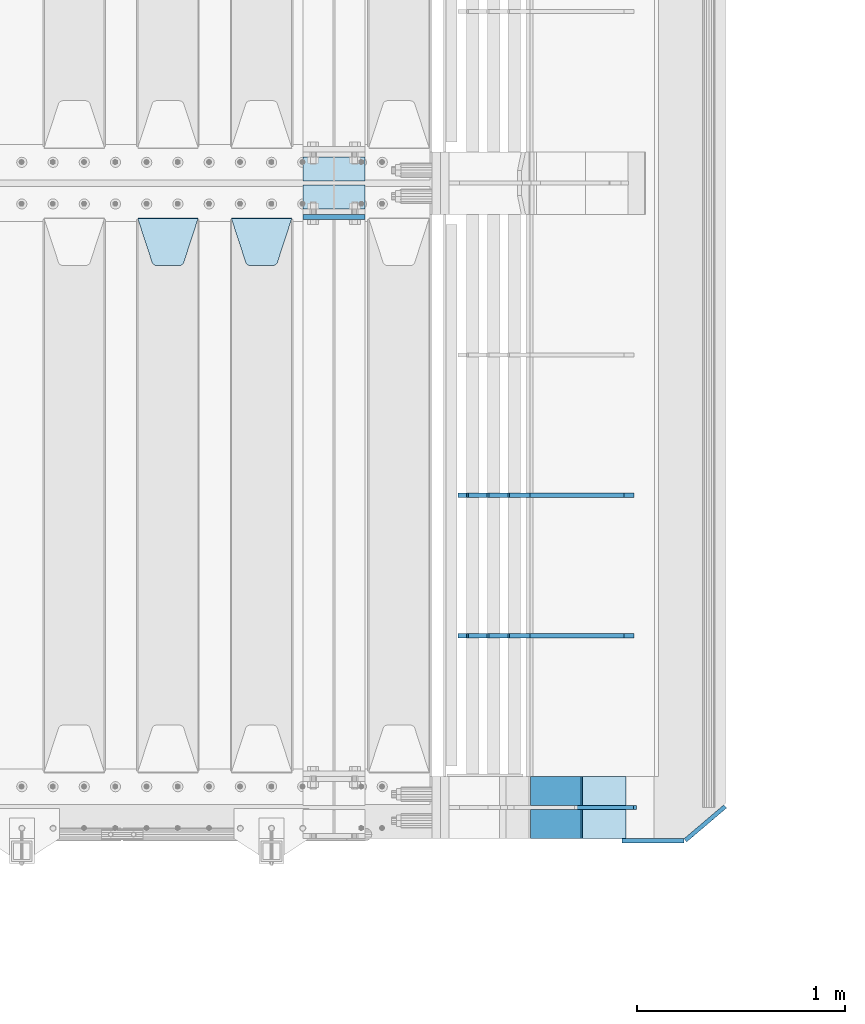
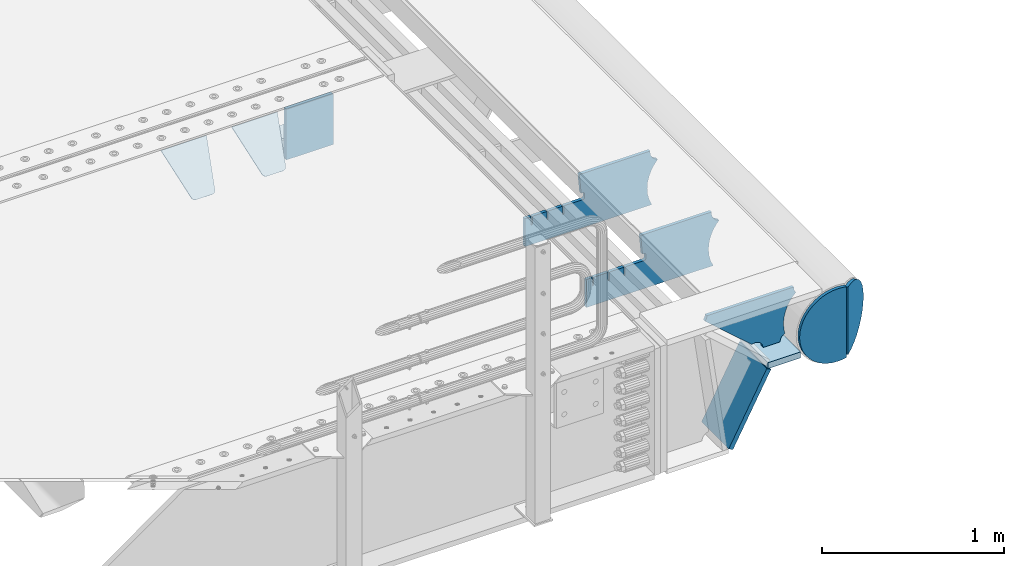
# One storey, part 220 of 242: 12 plates.
"""IFC2X3 building model written with IfcOpenShell, lengths in millimetres."""

from ifc_helpers import new_model, si_unit, frame, origin_with_axes, place, context, subcontext, project, spatial, faceted_brep, material, type_object, element, save


model = new_model("IFC2X3")

# Units and contexts
model_context = context("Model", 3, precision=1e-05, world=origin_with_axes())
body_context = subcontext(model_context, "Body", "Model", "MODEL_VIEW")
ifc_project = project(units=[si_unit("LENGTHUNIT", "METRE", prefix="MILLI"), si_unit("AREAUNIT", "SQUARE_METRE"), si_unit("VOLUMEUNIT", "CUBIC_METRE"), si_unit("MASSUNIT", "GRAM", prefix="KILO"), si_unit("TIMEUNIT", "SECOND"), si_unit("PLANEANGLEUNIT", "RADIAN"), si_unit("SOLIDANGLEUNIT", "STERADIAN"), si_unit("THERMODYNAMICTEMPERATUREUNIT", "DEGREE_CELSIUS"), si_unit("LUMINOUSINTENSITYUNIT", "LUMEN")], contexts=[model_context])

# Site, building, storey
site_placement = place(None, origin_with_axes())
site = spatial("IfcSite", under=ifc_project, at=site_placement, CompositionType="ELEMENT")
building_placement = place(site_placement, origin_with_axes())
building = spatial("IfcBuilding", under=site, at=building_placement, Name="Standard", CompositionType="ELEMENT")
storey_placement = place(building_placement, origin_with_axes())
storey = spatial("IfcBuildingStorey", under=building, at=storey_placement, Name="Undefined", CompositionType="ELEMENT", Elevation=0.0)

# Plates
ifc_material = material(Name="STEEL/S355N")
plate_type_1 = type_object("IfcPlateType", PredefinedType="NOTDEFINED")
plate_1_placement = place(storey_placement, frame((-22682.0, -21162.5, -340.000000000044), z_axis=(0.0, 0.0, 1.0), x_axis=(1.0, 0.0, 0.0)))
element("IfcPlate", 1, at=plate_1_placement, inside=storey, type_object=plate_type_1, material=ifc_material, context=body_context, shape_type="Brep", body=[
    faceted_brep([(0.0, -12.5, 0.0), (9.27684595808387e-10, -12.5, 340.0), (9.27684595808387e-10, 12.5, 340.0), (0.0, 12.5, 0.0), (300.0, -12.5, 340.0), (300.0, 12.5, 340.0), (300.0, -12.5, 0.0), (300.0, 12.5, 0.0)], [[[0, 1, 2, 3]], [[1, 4, 5, 2]], [[4, 6, 7, 5]], [[6, 0, 3, 7]], [[5, 7, 3, 2]], [[6, 4, 1, 0]]]),
])
plate_type_2 = type_object("IfcPlateType", PredefinedType="NOTDEFINED")
plate_2_placement = place(storey_placement, frame((-23025.0, -21168.232233044, -1.76776695296576), z_axis=(0.0, -0.707106781186547, -0.707106781186548), x_axis=(1.0, 0.0, 0.0)))
element("IfcPlate", 2, at=plate_2_placement, inside=storey, type_object=plate_type_2, material=ifc_material, context=body_context, shape_type="Brep", body=[
    faceted_brep([(0.0, -2.5, 0.0), (69.345504679477, -2.50000000000182, 300.171731424829), (69.345504679477, 2.5, 300.171731424829), (0.0, 2.5, 0.0), (70.9274061199576, -2.5, 304.897442415398), (70.9274061199576, 2.5, 304.897442415398), (73.3818627772307, -2.5, 309.234538108525), (73.3818627772307, 2.50000000000182, 309.234538108529), (76.6187032999551, -2.5, 313.023683126101), (76.6187032999551, 2.50000000000182, 313.023683126103), (80.5190132704993, -2.5, 316.12567259537), (80.5190132704993, 2.5, 316.12567259537), (84.9395038596849, -2.5, 318.426546230474), (84.9395038596849, 2.50000000000182, 318.426546230476), (89.7177759439219, -2.49999999999818, 319.841774983273), (89.7177759439219, 2.50000000000182, 319.841774983273), (94.678286292652, -2.5, 320.319366455076), (94.678286292652, 2.5, 320.319366455076), (195.321713707348, -2.5, 320.319366455076), (195.321713707348, 2.5, 320.319366455076), (200.282224056078, -2.5, 319.841774983272), (200.282224056078, 2.50000000000182, 319.841774983273), (205.060496140315, -2.5, 318.426546230474), (205.060496140315, 2.49999999999818, 318.426546230474), (209.480986729501, -2.49999999999818, 316.12567259537), (209.480986729501, 2.5, 316.12567259537), (213.381296700045, -2.5, 313.023683126101), (213.381296700045, 2.49999999999818, 313.023683126101), (216.618137222769, -2.5, 309.234538108525), (216.618137222769, 2.5, 309.234538108523), (219.072593880042, -2.49999999999818, 304.897442415398), (219.072593880042, 2.50000000000182, 304.897442415398), (220.654495320523, -2.50000000000182, 300.171731424829), (220.654495320523, 2.5, 300.171731424829), (290.0, -2.5, 0.0), (290.0, 2.5, -1.81898940354586e-12)], [[[0, 1, 2, 3]], [[1, 4, 5, 2]], [[4, 6, 7, 5]], [[6, 8, 9, 7]], [[8, 10, 11, 9]], [[10, 12, 13, 11]], [[12, 14, 15, 13]], [[14, 16, 17, 15]], [[16, 18, 19, 17]], [[18, 20, 21, 19]], [[20, 22, 23, 21]], [[22, 24, 25, 23]], [[24, 26, 27, 25]], [[26, 28, 29, 27]], [[28, 30, 31, 29]], [[30, 32, 33, 31]], [[32, 34, 35, 33]], [[34, 0, 3, 35]], [[5, 7, 9, 11, 13, 15, 17, 19, 21, 23, 25, 27, 29, 31, 33, 35, 3, 2]], [[34, 32, 30, 28, 26, 24, 22, 20, 18, 16, 14, 12, 10, 8, 6, 4, 1, 0]]]),
])
plate_3_placement = place(storey_placement, frame((-23475.0, -21168.232233044, -1.76776695296576), z_axis=(0.0, -0.707106781186547, -0.707106781186548), x_axis=(1.0, 0.0, 0.0)))
element("IfcPlate", 3, at=plate_3_placement, inside=storey, type_object=plate_type_2, material=ifc_material, context=body_context, shape_type="Brep", body=[
    faceted_brep([(0.0, -2.5, 0.0), (69.345504679477, -2.50000000000182, 300.171731424829), (69.345504679477, 2.5, 300.171731424829), (0.0, 2.5, 0.0), (70.9274061199576, -2.5, 304.897442415398), (70.9274061199576, 2.5, 304.897442415398), (73.3818627772307, -2.5, 309.234538108525), (73.3818627772307, 2.50000000000182, 309.234538108529), (76.6187032999551, -2.5, 313.023683126101), (76.6187032999551, 2.50000000000182, 313.023683126103), (80.5190132704993, -2.5, 316.12567259537), (80.5190132704993, 2.5, 316.12567259537), (84.9395038596849, -2.5, 318.426546230474), (84.9395038596849, 2.50000000000182, 318.426546230476), (89.7177759439219, -2.49999999999818, 319.841774983273), (89.7177759439219, 2.50000000000182, 319.841774983273), (94.678286292652, -2.5, 320.319366455076), (94.678286292652, 2.5, 320.319366455076), (195.321713707348, -2.5, 320.319366455076), (195.321713707348, 2.5, 320.319366455076), (200.282224056078, -2.5, 319.841774983272), (200.282224056078, 2.50000000000182, 319.841774983273), (205.060496140315, -2.5, 318.426546230474), (205.060496140315, 2.49999999999818, 318.426546230474), (209.480986729501, -2.49999999999818, 316.12567259537), (209.480986729501, 2.5, 316.12567259537), (213.381296700045, -2.5, 313.023683126101), (213.381296700045, 2.49999999999818, 313.023683126101), (216.618137222769, -2.5, 309.234538108525), (216.618137222769, 2.5, 309.234538108523), (219.072593880042, -2.49999999999818, 304.897442415398), (219.072593880042, 2.50000000000182, 304.897442415398), (220.654495320523, -2.50000000000182, 300.171731424829), (220.654495320523, 2.5, 300.171731424829), (290.0, -2.5, 0.0), (290.0, 2.5, -1.81898940354586e-12)], [[[0, 1, 2, 3]], [[1, 4, 5, 2]], [[4, 6, 7, 5]], [[6, 8, 9, 7]], [[8, 10, 11, 9]], [[10, 12, 13, 11]], [[12, 14, 15, 13]], [[14, 16, 17, 15]], [[16, 18, 19, 17]], [[18, 20, 21, 19]], [[20, 22, 23, 21]], [[22, 24, 25, 23]], [[24, 26, 27, 25]], [[26, 28, 29, 27]], [[28, 30, 31, 29]], [[30, 32, 33, 31]], [[32, 34, 35, 33]], [[34, 0, 3, 35]], [[5, 7, 9, 11, 13, 15, 17, 19, 21, 23, 25, 27, 29, 31, 33, 35, 3, 2]], [[34, 32, 30, 28, 26, 24, 22, 20, 18, 16, 14, 12, 10, 8, 6, 4, 1, 0]]]),
])
plate_type_3 = type_object("IfcPlateType", PredefinedType="NOTDEFINED")
plate_4_placement = place(storey_placement, frame((-21338.0011701102, -24150.0000000008, -387.999999998984), z_axis=(1.0, 0.0, 0.0), x_axis=(0.0, 1.0, 0.0)))
element("IfcPlate", 4, at=plate_4_placement, inside=storey, type_object=plate_type_3, material=ifc_material, context=body_context, shape_type="Brep", body=[
    faceted_brep([(0.0, -20.0, 0.0), (3.31056071445346e-10, -20.0, 208.0), (3.31056071445346e-10, 20.0, 208.0), (0.0, 20.0, 0.0), (300.0, -20.0, 208.0), (300.0, 20.0, 208.0), (300.0, -20.0, 3.63797880709171e-12), (300.0, 20.0, 3.63797880709171e-12)], [[[0, 1, 2, 3]], [[1, 4, 5, 2]], [[4, 6, 7, 5]], [[6, 0, 3, 7]], [[5, 7, 3, 2]], [[6, 4, 1, 0]]]),
])
plate_type_4 = type_object("IfcPlateType", PredefinedType="NOTDEFINED")
plate_5_placement = place(storey_placement, frame((-21573.7531990427, -23849.999999999, -867.038754737719), z_axis=(0.469471552246176, 0.0, 0.882947598462992), x_axis=(0.0, -1.0, 0.0)))
element("IfcPlate", 5, at=plate_5_placement, inside=storey, type_object=plate_type_4, material=ifc_material, context=body_context, shape_type="Brep", body=[
    faceted_brep([(0.0, -15.0, 0.0), (0.0, -15.0000000000036, 515.0), (0.0, 15.0, 515.000000000002), (0.0, 15.0, 0.0), (300.0, -15.0000000000036, 515.0), (300.0, 15.0, 515.000000000002), (300.0, -15.0, 0.0), (300.0, 15.0, 0.0)], [[[0, 1, 2, 3]], [[1, 4, 5, 2]], [[4, 6, 7, 5]], [[6, 0, 3, 7]], [[5, 7, 3, 2]], [[6, 4, 1, 0]]]),
])
plate_type_5 = type_object("IfcPlateType", PredefinedType="NOTDEFINED")
plate_6_placement = place(storey_placement, frame((-21023.0011701102, -24000.0000000006, -29.9999999989843), z_axis=(-0.000446694000102124, 0.0, -0.99999990023223), x_axis=(-0.99999990023223, 0.0, 0.000446694000103734)))
element("IfcPlate", 6, at=plate_6_placement, inside=storey, type_object=plate_type_5, material=ifc_material, context=body_context, shape_type="Brep", body=[
    faceted_brep([(125.007775472979, 10.0, 291.842314882029), (131.755016800049, 10.0, 263.793234614468), (131.755016800049, -10.0, 263.793234614468), (125.007775472979, -10.0, 291.842314882029), (134.899927074479, 10.0, 224.060281342732), (134.899927074479, -10.0, 224.060281342732), (131.790514995217, 10.0, 184.324534302446), (131.790514995217, -10.0, 184.324534302446), (122.503344607205, 10.0, 145.564419461128), (122.503344607205, -10.0, 145.564419461128), (107.267096867741, 10.0, 108.734339483615), (107.267096867741, -10.0, 108.734339483615), (86.4569387623887, 10.0, 74.7411731709829), (86.4569387623887, -10.0, 74.7411731709829), (60.5852854486475, 10.0, 44.4219450946983), (60.5852854486475, -10.0, 44.4219450946983), (56.2519855253086, 10.0, 40.7176084148888), (56.2519855253086, -10.0, 40.7176084148888), (136.409234539125, -10.0, 297.721677540594), (147.386991180581, -10.0, 308.778803581017), (147.386991180581, 10.0, 308.778803581017), (136.409234539125, 10.0, 297.721677540594), (154.428166132755, -10.0, 322.678193223937), (154.428166132755, 10.0, 322.678193223937), (156.849001662973, -10.0, 338.070097995228), (156.849001662973, 10.0, 338.070097995228), (264.849004013293, -10.0, 338.118348049693), (264.849004013293, 10.0, 338.118348049693), (267.62876711955, -10.0, 321.701412969031), (267.62876711955, 10.0, 321.701412969031), (275.645118712175, -10.0, 307.107546191754), (275.645118712175, 10.0, 307.107546191754), (288.009068357209, -10.0, 295.955165748785), (288.009068357209, 10.0, 295.955165748785), (303.34948944753, -10.0, 289.481038692482), (303.34948944753, 10.0, 289.481038692482), (319.965173216922, -10.0, 288.403127172445), (319.965173216922, 10.0, 288.403127172445), (336.013487920231, -10.0, 292.840968489265), (336.013487920231, 10.0, 292.840968489265), (335.86907958984, -10.0, 293.150054931641), (335.86907958984, 10.0, 293.150054931641), (633.93705743644, -10.0, 32.8861672876964), (633.93705743644, 10.0, 32.8861672876964), (628.672097726398, -10.0, 25.6357574923157), (628.672097726398, 10.0, 25.6357574923157), (624.785781531267, -10.0, 17.5620477266101), (624.785781531267, 10.0, 17.5620477266101), (622.402919050597, -10.0, 8.92432757904925), (622.402919050597, 10.0, 8.92432757904925), (621.600036621094, -10.0, -8.74685213148041e-10), (621.600036621094, 10.0, -8.74685213148041e-10), (69.9999999999964, -10.0, -9.85096448857803e-11), (69.9999999999964, 10.0, -9.85096448857803e-11), (67.7728137216582, -10.0, 17.5170123094482), (67.7728137216582, 10.0, 17.5170123094482), (61.2329794213947, -10.0, 33.9193489203214), (61.2329794213947, 10.0, 33.9193489203214)], [[[0, 1, 2, 3]], [[4, 5, 2, 1]], [[6, 7, 5, 4]], [[8, 9, 7, 6]], [[10, 11, 9, 8]], [[12, 13, 11, 10]], [[14, 15, 13, 12]], [[16, 17, 15, 14]], [[18, 19, 20, 21]], [[19, 22, 23, 20]], [[22, 24, 25, 23]], [[24, 26, 27, 25]], [[26, 28, 29, 27]], [[28, 30, 31, 29]], [[30, 32, 33, 31]], [[32, 34, 35, 33]], [[34, 36, 37, 35]], [[36, 38, 39, 37]], [[38, 40, 41, 39]], [[40, 42, 43, 41]], [[42, 44, 45, 43]], [[44, 46, 47, 45]], [[46, 48, 49, 47]], [[48, 50, 51, 49]], [[50, 52, 53, 51]], [[52, 54, 55, 53]], [[54, 56, 57, 55]], [[12, 10, 8, 6, 4, 1, 0, 21, 20, 23, 25, 27, 29, 31, 33, 35, 37, 39, 41, 43, 45, 47, 49, 51, 53, 55, 57, 16, 14]], [[18, 21, 0, 3]], [[56, 54, 52, 50, 48, 46, 44, 42, 40, 38, 36, 34, 32, 30, 28, 26, 24, 22, 19, 18, 3, 2, 5, 7, 9, 11, 13, 15, 17]], [[57, 56, 17, 16]]]),
])
plate_type_6 = type_object("IfcPlateType", PredefinedType="NOTDEFINED")
plate_7_placement = place(storey_placement, frame((-21094.0817660324, -23175.0007171631, -374.002067436517), z_axis=(0.0, 0.0, 1.0), x_axis=(-1.0, 0.0, 0.0)))
element("IfcPlate", 7, at=plate_7_placement, inside=storey, type_object=plate_type_6, material=ifc_material, context=body_context, shape_type="Brep", body=[
    faceted_brep([(801.919404066546, -10.0, 188.0), (801.919404066546, 10.0, 188.0), (801.919404066546, 10.0, 132.002067436952), (801.919404066546, -10.0, 132.002067436952), (793.919404066546, 10.0, 132.002067436952), (793.919404066546, -10.0, 132.002067436952), (793.919404066546, 10.0, 180.002067436952), (793.919404066546, -10.0, 180.002067436952), (793.527856196906, 10.0, 182.474203391951), (793.527856196906, -10.0, 182.474203391951), (792.391540021545, 10.0, 184.704349455291), (792.391540021545, -10.0, 184.704349455291), (790.621686084887, 10.0, 186.474203391951), (790.621686084887, -10.0, 186.474203391951), (788.391540021545, 10.0, 187.610519567313), (788.391540021545, -10.0, 187.610519567313), (785.919404066546, -10.0, 188.002067436952), (785.919404066546, 10.0, 188.0), (841.0, -10.0, 188.0), (841.0, -10.0, 0.0), (841.0, 10.0, 0.0), (841.0, 10.0, 188.0), (33.3619566735979, -10.0, 0.0), (33.3619566735979, 10.0, 0.0), (36.2350612208174, -10.0, 4.68848050267007), (36.2350612208174, 10.0, 4.68848050267007), (51.4877592159428, -10.0, 41.5117508652783), (51.4877592159428, 10.0, 41.5117508652783), (60.792242588137, -10.0, 80.2677133162963), (60.792242588137, 10.0, 80.2677133162963), (63.9194040769726, -10.0, 120.002067436515), (63.9194040769726, 10.0, 120.002067436515), (60.792242588137, -10.0, 159.736421556734), (60.792242588137, 10.0, 159.736421556734), (51.4877592159428, -10.0, 198.492384007752), (51.4877592159428, 10.0, 198.492384007752), (36.2350612208174, -10.0, 235.31565437036), (36.2350612208174, 10.0, 235.31565437036), (15.4097206482074, -10.0, 269.299521518803), (15.4097206482074, 10.0, 269.299521518803), (-3.35474438098754, -10.0, 291.269887256574), (-3.35474438098754, 10.0, 291.269887256574), (-2.36881039375294, -10.0, 291.426043859339), (-2.36881039375294, 10.0, 291.426043859339), (17.1449676604716, -10.0, 301.368810393754), (17.1449676604716, 10.0, 301.368810393754), (32.6311896062471, -10.0, 316.855032339527), (32.6311896062471, 10.0, 316.855032339527), (42.573956140659, -10.0, 336.368810393754), (42.573956140659, 10.0, 336.368810393754), (46.0, -10.0, 358.0), (46.0, 10.0, 358.0), (45.0495205499137, -10.0, 364.001091067617), (45.0495205499137, 10.0, 364.001091067617), (495.040008544922, -10.0, 364.010009765625), (495.040008544922, 10.0, 364.010009765625), (483.600036621094, -10.0, 233.759994506836), (483.600036621094, 10.0, 233.759994506836), (472.0, -10.0, 233.759994506836), (472.0, 10.0, 233.759994506836), (468.909830056251, -10.0, 233.270559669787), (468.909830056251, 10.0, 233.270559669787), (466.122147477075, -10.0, 231.850164450585), (466.122147477075, 10.0, 231.850164450585), (463.909830056251, -10.0, 229.637847029761), (463.909830056251, 10.0, 229.637847029761), (462.489434837047, -10.0, 226.850164450585), (462.489434837047, 10.0, 226.850164450585), (462.0, -10.0, 223.759994506836), (462.0, 10.0, 223.759994506836), (462.0, -10.0, 198.0), (462.0, 10.0, 198.0), (462.489434837047, -10.0, 194.909830056251), (462.489434837047, 10.0, 194.909830056251), (463.909830056251, -10.0, 192.122147477075), (463.909830056251, 10.0, 192.122147477075), (466.122147477075, -10.0, 189.909830056251), (466.122147477075, 10.0, 189.909830056251), (468.909830056251, -10.0, 188.489434837048), (468.909830056251, 10.0, 188.489434837048), (472.0, -10.0, 188.0), (472.0, 10.0, 188.0), (585.919404066546, -10.0, 188.002067436952), (585.919404066546, 10.0, 188.0), (588.391540021545, -10.0, 187.610519567313), (588.391540021545, 10.0, 187.610519567313), (590.621686084887, -10.0, 186.474203391951), (590.621686084887, 10.0, 186.474203391951), (592.391540021545, -10.0, 184.704349455291), (592.391540021545, 10.0, 184.704349455291), (593.527856196906, -10.0, 182.474203391951), (593.527856196906, 10.0, 182.474203391951), (593.919404066546, -10.0, 180.002067436952), (593.919404066546, 10.0, 180.002067436952), (593.919404066546, -10.0000000000036, 132.002067436952), (593.919404066546, 10.0, 132.002067436952), (601.919404066546, -10.0000000000036, 132.002067436952), (601.919404066546, 10.0, 132.002067436952), (601.919404066546, -10.0, 188.0), (601.919404066546, 10.0, 188.0), (685.919404066546, -10.0, 188.002067436952), (685.919404066546, 10.0, 188.0), (688.391540021545, -10.0, 187.610519567313), (688.391540021545, 10.0, 187.610519567313), (690.621686084887, -10.0, 186.474203391951), (690.621686084887, 10.0, 186.474203391951), (692.391540021545, -10.0, 184.704349455291), (692.391540021545, 10.0, 184.704349455291), (693.527856196906, -10.0, 182.474203391951), (693.527856196906, 10.0, 182.474203391951), (693.919404066546, -10.0, 180.002067436952), (693.919404066546, 10.0, 180.002067436952), (693.919404066546, -10.0, 132.002067436952), (693.919404066546, 10.0, 132.002067436952), (701.919404066546, -10.0, 132.002067436952), (701.919404066546, 10.0, 132.002067436952), (701.919404066546, -10.0, 188.0), (701.919404066546, 10.0, 188.0)], [[[0, 1, 2, 3]], [[3, 2, 4, 5]], [[5, 4, 6, 7]], [[7, 6, 8, 9]], [[9, 8, 10, 11]], [[11, 10, 12, 13]], [[13, 12, 14, 15]], [[16, 15, 14, 17]], [[18, 19, 20, 21]], [[20, 19, 22, 23]], [[22, 24, 25, 23]], [[26, 27, 25, 24]], [[28, 29, 27, 26]], [[30, 31, 29, 28]], [[32, 33, 31, 30]], [[34, 35, 33, 32]], [[36, 37, 35, 34]], [[38, 39, 37, 36]], [[39, 38, 40, 41]], [[40, 42, 43, 41]], [[44, 45, 43, 42]], [[46, 47, 45, 44]], [[48, 49, 47, 46]], [[50, 51, 49, 48]], [[52, 53, 51, 50]], [[54, 55, 53, 52]], [[54, 56, 57, 55]], [[56, 58, 59, 57]], [[58, 60, 61, 59]], [[60, 62, 63, 61]], [[62, 64, 65, 63]], [[64, 66, 67, 65]], [[66, 68, 69, 67]], [[68, 70, 71, 69]], [[70, 72, 73, 71]], [[72, 74, 75, 73]], [[74, 76, 77, 75]], [[76, 78, 79, 77]], [[78, 80, 81, 79]], [[81, 80, 82, 83]], [[82, 84, 85, 83]], [[86, 87, 85, 84]], [[88, 89, 87, 86]], [[90, 91, 89, 88]], [[92, 93, 91, 90]], [[94, 95, 93, 92]], [[96, 97, 95, 94]], [[98, 99, 97, 96]], [[99, 98, 100, 101]], [[100, 102, 103, 101]], [[104, 105, 103, 102]], [[106, 107, 105, 104]], [[108, 109, 107, 106]], [[110, 111, 109, 108]], [[112, 113, 111, 110]], [[114, 115, 113, 112]], [[116, 117, 115, 114]], [[117, 116, 16, 17]], [[12, 10, 8, 6, 4, 2, 1, 21, 20, 23, 25, 27, 29, 31, 33, 35, 37, 39, 41, 43, 45, 47, 49, 51, 53, 55, 57, 59, 61, 63, 65, 67, 69, 71, 73, 75, 77, 79, 81, 83, 85, 87, 89, 91, 93, 95, 97, 99, 101, 103, 105, 107, 109, 111, 113, 115, 117, 17, 14]], [[18, 21, 1, 0]], [[116, 114, 112, 110, 108, 106, 104, 102, 100, 98, 96, 94, 92, 90, 88, 86, 84, 82, 80, 78, 76, 74, 72, 70, 68, 66, 64, 62, 60, 58, 56, 54, 52, 50, 48, 46, 44, 42, 40, 38, 36, 34, 32, 30, 28, 26, 24, 22, 19, 18, 0, 3, 5, 7, 9, 11, 13, 15, 16]]]),
])
plate_8_placement = place(storey_placement, frame((-21094.0817660324, -22500.0007171631, -374.002067436517), z_axis=(0.0, 0.0, 1.0), x_axis=(-1.0, 0.0, 0.0)))
element("IfcPlate", 8, at=plate_8_placement, inside=storey, type_object=plate_type_6, material=ifc_material, context=body_context, shape_type="Brep", body=[
    faceted_brep([(801.919404066546, -10.0, 188.0), (801.919404066546, 10.0, 188.0), (801.919404066546, 10.0, 132.002067436952), (801.919404066546, -10.0, 132.002067436952), (793.919404066546, 10.0, 132.002067436952), (793.919404066546, -10.0, 132.002067436952), (793.919404066546, 10.0, 180.002067436952), (793.919404066546, -10.0, 180.002067436952), (793.527856196906, 10.0, 182.474203391951), (793.527856196906, -10.0, 182.474203391951), (792.391540021545, 10.0, 184.704349455291), (792.391540021545, -10.0, 184.704349455291), (790.621686084887, 10.0, 186.474203391951), (790.621686084887, -10.0, 186.474203391951), (788.391540021545, 10.0, 187.610519567313), (788.391540021545, -10.0, 187.610519567313), (785.919404066546, -10.0, 188.002067436952), (785.919404066546, 10.0, 188.0), (841.0, -10.0, 188.0), (841.0, -10.0, 0.0), (841.0, 10.0, 0.0), (841.0, 10.0, 188.0), (33.3619566735979, -10.0, 0.0), (33.3619566735979, 10.0, 0.0), (36.2350612208174, -10.0, 4.68848050267007), (36.2350612208174, 10.0, 4.68848050267007), (51.4877592159428, -10.0, 41.5117508652783), (51.4877592159428, 10.0, 41.5117508652783), (60.792242588137, -10.0, 80.2677133162963), (60.792242588137, 10.0, 80.2677133162963), (63.9194040769726, -10.0, 120.002067436515), (63.9194040769726, 10.0, 120.002067436515), (60.792242588137, -10.0, 159.736421556734), (60.792242588137, 10.0, 159.736421556734), (51.4877592159428, -10.0, 198.492384007752), (51.4877592159428, 10.0, 198.492384007752), (36.2350612208174, -10.0, 235.31565437036), (36.2350612208174, 10.0, 235.31565437036), (15.4097206482074, -10.0, 269.299521518803), (15.4097206482074, 10.0, 269.299521518803), (-3.35474438098754, -10.0, 291.269887256574), (-3.35474438098754, 10.0, 291.269887256574), (-2.36881039375294, -10.0, 291.426043859339), (-2.36881039375294, 10.0, 291.426043859339), (17.1449676604716, -10.0, 301.368810393754), (17.1449676604716, 10.0, 301.368810393754), (32.6311896062471, -10.0, 316.855032339527), (32.6311896062471, 10.0, 316.855032339527), (42.573956140659, -10.0, 336.368810393754), (42.573956140659, 10.0, 336.368810393754), (46.0, -10.0, 358.0), (46.0, 10.0, 358.0), (45.0495205499137, -10.0, 364.001091067617), (45.0495205499137, 10.0, 364.001091067617), (495.040008544922, -10.0, 364.010009765625), (495.040008544922, 10.0, 364.010009765625), (483.600036621094, -10.0, 233.759994506836), (483.600036621094, 10.0, 233.759994506836), (472.0, -10.0, 233.759994506836), (472.0, 10.0, 233.759994506836), (468.909830056251, -10.0, 233.270559669787), (468.909830056251, 10.0, 233.270559669787), (466.122147477075, -10.0, 231.850164450585), (466.122147477075, 10.0, 231.850164450585), (463.909830056251, -10.0, 229.637847029761), (463.909830056251, 10.0, 229.637847029761), (462.489434837047, -10.0, 226.850164450585), (462.489434837047, 10.0, 226.850164450585), (462.0, -10.0, 223.759994506836), (462.0, 10.0, 223.759994506836), (462.0, -10.0, 198.0), (462.0, 10.0, 198.0), (462.489434837047, -10.0, 194.909830056251), (462.489434837047, 10.0, 194.909830056251), (463.909830056251, -10.0, 192.122147477075), (463.909830056251, 10.0, 192.122147477075), (466.122147477075, -10.0, 189.909830056251), (466.122147477075, 10.0, 189.909830056251), (468.909830056251, -10.0, 188.489434837048), (468.909830056251, 10.0, 188.489434837048), (472.0, -10.0, 188.0), (472.0, 10.0, 188.0), (585.919404066546, -10.0, 188.002067436952), (585.919404066546, 10.0, 188.0), (588.391540021545, -10.0, 187.610519567313), (588.391540021545, 10.0, 187.610519567313), (590.621686084887, -10.0, 186.474203391951), (590.621686084887, 10.0, 186.474203391951), (592.391540021545, -10.0, 184.704349455291), (592.391540021545, 10.0, 184.704349455291), (593.527856196906, -10.0, 182.474203391951), (593.527856196906, 10.0, 182.474203391951), (593.919404066546, -10.0, 180.002067436952), (593.919404066546, 10.0, 180.002067436952), (593.919404066546, -10.0000000000036, 132.002067436952), (593.919404066546, 10.0, 132.002067436952), (601.919404066546, -10.0000000000036, 132.002067436952), (601.919404066546, 10.0, 132.002067436952), (601.919404066546, -10.0, 188.0), (601.919404066546, 10.0, 188.0), (685.919404066546, -10.0, 188.002067436952), (685.919404066546, 10.0, 188.0), (688.391540021545, -10.0, 187.610519567313), (688.391540021545, 10.0, 187.610519567313), (690.621686084887, -10.0, 186.474203391951), (690.621686084887, 10.0, 186.474203391951), (692.391540021545, -10.0, 184.704349455291), (692.391540021545, 10.0, 184.704349455291), (693.527856196906, -10.0, 182.474203391951), (693.527856196906, 10.0, 182.474203391951), (693.919404066546, -10.0, 180.002067436952), (693.919404066546, 10.0, 180.002067436952), (693.919404066546, -10.0, 132.002067436952), (693.919404066546, 10.0, 132.002067436952), (701.919404066546, -10.0, 132.002067436952), (701.919404066546, 10.0, 132.002067436952), (701.919404066546, -10.0, 188.0), (701.919404066546, 10.0, 188.0)], [[[0, 1, 2, 3]], [[3, 2, 4, 5]], [[5, 4, 6, 7]], [[7, 6, 8, 9]], [[9, 8, 10, 11]], [[11, 10, 12, 13]], [[13, 12, 14, 15]], [[16, 15, 14, 17]], [[18, 19, 20, 21]], [[20, 19, 22, 23]], [[22, 24, 25, 23]], [[26, 27, 25, 24]], [[28, 29, 27, 26]], [[30, 31, 29, 28]], [[32, 33, 31, 30]], [[34, 35, 33, 32]], [[36, 37, 35, 34]], [[38, 39, 37, 36]], [[39, 38, 40, 41]], [[40, 42, 43, 41]], [[44, 45, 43, 42]], [[46, 47, 45, 44]], [[48, 49, 47, 46]], [[50, 51, 49, 48]], [[52, 53, 51, 50]], [[54, 55, 53, 52]], [[54, 56, 57, 55]], [[56, 58, 59, 57]], [[58, 60, 61, 59]], [[60, 62, 63, 61]], [[62, 64, 65, 63]], [[64, 66, 67, 65]], [[66, 68, 69, 67]], [[68, 70, 71, 69]], [[70, 72, 73, 71]], [[72, 74, 75, 73]], [[74, 76, 77, 75]], [[76, 78, 79, 77]], [[78, 80, 81, 79]], [[81, 80, 82, 83]], [[82, 84, 85, 83]], [[86, 87, 85, 84]], [[88, 89, 87, 86]], [[90, 91, 89, 88]], [[92, 93, 91, 90]], [[94, 95, 93, 92]], [[96, 97, 95, 94]], [[98, 99, 97, 96]], [[99, 98, 100, 101]], [[100, 102, 103, 101]], [[104, 105, 103, 102]], [[106, 107, 105, 104]], [[108, 109, 107, 106]], [[110, 111, 109, 108]], [[112, 113, 111, 110]], [[114, 115, 113, 112]], [[116, 117, 115, 114]], [[117, 116, 16, 17]], [[12, 10, 8, 6, 4, 2, 1, 21, 20, 23, 25, 27, 29, 31, 33, 35, 37, 39, 41, 43, 45, 47, 49, 51, 53, 55, 57, 59, 61, 63, 65, 67, 69, 71, 73, 75, 77, 79, 81, 83, 85, 87, 89, 91, 93, 95, 97, 99, 101, 103, 105, 107, 109, 111, 113, 115, 117, 17, 14]], [[18, 21, 1, 0]], [[116, 114, 112, 110, 108, 106, 104, 102, 100, 98, 96, 94, 92, 90, 88, 86, 84, 82, 80, 78, 76, 74, 72, 70, 68, 66, 64, 62, 60, 58, 56, 54, 52, 50, 48, 46, 44, 42, 40, 38, 36, 34, 32, 30, 28, 26, 24, 22, 19, 18, 0, 3, 5, 7, 9, 11, 13, 15, 16]]]),
])
plate_type_7 = type_object("IfcPlateType", PredefinedType="NOTDEFINED")
plate_9_placement = place(storey_placement, frame((-20659.9974739935, -24160.0, -498.0), z_axis=(0.0, 0.0, 1.0), x_axis=(-1.0, 0.0, 0.0)))
element("IfcPlate", 9, at=plate_9_placement, inside=storey, type_object=plate_type_7, material=ifc_material, context=body_context, shape_type="Brep", body=[
    faceted_brep([(244.0, -10.0, 0.0), (209.275179461318, -10.0, 2.48356818105242), (209.275179461318, 10.0, 2.48356818105242), (244.0, 10.0, 0.0), (278.724820538682, -10.0, 2.48356818105236), (278.724820538682, 10.0, 2.48356818105236), (312.742743869308, -10.0, 9.88371443806261), (312.742743869308, 10.0, 9.88371443806261), (345.361263172461, -10.0, 22.0497931334975), (345.361263172461, 10.0, 22.0497931334975), (375.916359459166, -10.0, 38.7341379891918), (375.916359459166, 10.0, 38.7341379891918), (403.78601908265, -10.0, 59.597103857561), (403.78601908265, 10.0, 59.597103857561), (428.402896142437, -10.0, 84.2139809173505), (428.402896142437, 10.0, 84.2139809173505), (449.265862010809, -10.0, 112.083640540834), (449.265862010809, 10.0, 112.083640540834), (465.950206866502, -10.0, 142.63873682754), (465.950206866502, 10.0, 142.63873682754), (478.116285561937, -10.0, 175.257256130691), (478.116285561937, 10.0, 175.257256130691), (485.516431818949, -10.0, 209.275179461318), (485.516431818949, 10.0, 209.275179461318), (488.0, -10.0, 244.0), (488.0, 10.0, 244.0), (485.516431818949, -10.0, 278.724820538682), (485.516431818949, 10.0, 278.724820538682), (478.116285561937, -10.0, 312.742743869309), (478.116285561937, 10.0, 312.742743869309), (465.950206866502, -10.0, 345.36126317246), (465.950206866502, 10.0, 345.36126317246), (449.265862010809, -10.0, 375.916359459166), (449.265862010809, 10.0, 375.916359459166), (428.402896142437, -10.0, 403.78601908265), (428.402896142437, 10.0, 403.78601908265), (403.78601908265, -10.0, 428.402896142439), (403.78601908265, 10.0, 428.402896142439), (375.916359459166, -10.0, 449.265862010808), (375.916359459166, 10.0, 449.265862010808), (345.361263172461, -10.0, 465.950206866503), (345.361263172461, 10.0, 465.950206866503), (312.742743869308, -10.0, 478.116285561937), (312.742743869308, 10.0, 478.116285561937), (278.724820538682, -10.0, 485.516431818948), (278.724820538682, 10.0, 485.516431818948), (244.0, -10.0, 488.0), (244.0, 10.0, 488.0), (209.275179461318, -10.0, 485.516431818948), (209.275179461318, 10.0, 485.516431818948), (189.372062160266, -10.0, 481.186773668839), (189.375193030173, -10.0, 6.81254525210147), (189.379743036825, 10.0, 6.81155545873969), (189.376612153854, 10.0, 481.187763459359)], [[[0, 1, 2, 3]], [[4, 0, 3, 5]], [[6, 4, 5, 7]], [[8, 6, 7, 9]], [[10, 8, 9, 11]], [[12, 10, 11, 13]], [[14, 12, 13, 15]], [[16, 14, 15, 17]], [[18, 16, 17, 19]], [[20, 18, 19, 21]], [[22, 20, 21, 23]], [[24, 22, 23, 25]], [[26, 24, 25, 27]], [[28, 26, 27, 29]], [[30, 28, 29, 31]], [[32, 30, 31, 33]], [[34, 32, 33, 35]], [[36, 34, 35, 37]], [[38, 36, 37, 39]], [[40, 38, 39, 41]], [[42, 40, 41, 43]], [[44, 42, 43, 45]], [[46, 44, 45, 47]], [[48, 46, 47, 49]], [[1, 0, 4, 6, 8, 10, 12, 14, 16, 18, 20, 22, 24, 26, 28, 30, 32, 34, 36, 38, 40, 42, 44, 46, 48, 50, 51]], [[2, 1, 51, 52]], [[49, 47, 45, 43, 41, 39, 37, 35, 33, 31, 29, 27, 25, 23, 21, 19, 17, 15, 13, 11, 9, 7, 5, 3, 2, 52, 53]], [[48, 49, 53, 50]], [[52, 51, 50, 53]]]),
])
plate_type_8 = type_object("IfcPlateType", PredefinedType="NOTDEFINED")
plate_10_placement = place(storey_placement, frame((-20806.328144425, -24125.9492520076, -30.6102092804267), z_axis=(-0.0672019629768904, -0.0573522459802765, -0.996089662657469), x_axis=(-0.75895582087808, -0.64512069289632, 0.0883479119858049)))
element("IfcPlate", 10, at=plate_10_placement, inside=storey, type_object=plate_type_8, material=ifc_material, context=body_context, shape_type="Brep", body=[
    faceted_brep([(0.0, -10.0, 0.0), (-48.0487670880648, -10.00000000001, 8.6701745986943), (-48.0487670880611, 9.99999999999454, 8.6701745986943), (0.0, 10.0, 0.0), (-93.1333465523603, -10.0000000000036, 25.6771621704106), (-93.1333465523567, 9.99999999999454, 25.6771621704106), (-133.5220184223, -10.0000000000073, 50.3669776916513), (-133.522018422304, 9.99999999999272, 50.3669776916508), (-167.658004743993, -10.0000000000064, 81.7919921875005), (-167.658004743997, 9.99999999999363, 81.7919921875005), (-194.13117978525, -10.0000000000055, 118.752670288086), (-194.131179785254, 9.99999999999272, 118.752670288086), (-212.241073575682, -10.0000000000091, 159.800354003907), (-212.241073575675, 9.99999999999363, 159.800354003907), (-220.965927082383, -10.0000000000091, 203.387512207032), (-220.965927082379, 9.99999999999727, 203.387512207032), (-220.078811594765, -10.0000000000064, 247.82814025879), (-220.078811594765, 9.99999999999454, 247.82814025879), (-209.490798890532, -10.0000000000045, 291.426422119141), (-209.490798890529, 9.99999999999181, 291.426422119141), (-189.979858330364, -10.0000000000045, 332.473327636719), (-189.979858330367, 9.99999999999272, 332.473327636719), (-161.934860153855, -10.0000000000064, 369.423980712891), (-161.934860153859, 9.99999999999454, 369.423980712891), (-126.533912576622, -10.0000000000027, 400.848876953125), (-126.533912576626, 9.99999999999727, 400.848876953125), (-85.1552428327959, -10.0000000000082, 425.539093017579), (-85.1552428327996, 9.99999999999272, 425.539093017579), (-39.3886450815153, -10.0000000000064, 442.546478271484), (-39.3886450815116, 9.99999999999545, 442.546478271485), (8.9961729973511, -10.0000000000036, 451.215240478516), (8.99617299734382, 9.99999999999363, 451.215240478516), (49.169094085697, -10.0000000000082, -1.72803993336856e-11), (49.169094085697, 9.99999999999636, -1.68256519827992e-11)], [[[0, 1, 2, 3]], [[1, 4, 5, 2]], [[4, 6, 7, 5]], [[6, 8, 9, 7]], [[8, 10, 11, 9]], [[10, 12, 13, 11]], [[12, 14, 15, 13]], [[14, 16, 17, 15]], [[16, 18, 19, 17]], [[18, 20, 21, 19]], [[20, 22, 23, 21]], [[22, 24, 25, 23]], [[24, 26, 27, 25]], [[26, 28, 29, 27]], [[28, 30, 31, 29]], [[30, 32, 33, 31]], [[32, 0, 3, 33]], [[5, 7, 9, 11, 13, 15, 17, 19, 21, 23, 25, 27, 29, 31, 33, 3, 2]], [[32, 30, 28, 26, 24, 22, 20, 18, 16, 14, 12, 10, 8, 6, 4, 1, 0]]]),
])
plate_type_9 = type_object("IfcPlateType", PredefinedType="NOTDEFINED")
for number, where, z_axis, x_axis in (
    (11, (-22682.0, -20990.75, -342.99999999999), (0.0, 1.0, 0.0), (1.0, 0.0, 0.0)),
    (12, (-22682.0, -21009.25, -342.99999999999), (0.0, -1.0, 0.0), (1.0, 0.0, 0.0)),
):
    element("IfcPlate", number, at=place(storey_placement, frame(where, z_axis=z_axis, x_axis=x_axis)), inside=storey, type_object=plate_type_9, material=ifc_material, context=body_context, shape_type="Brep", body=[
        faceted_brep([(0.0, -7.0, 0.0), (0.0, -7.0, 115.75), (0.0, 7.0, 115.75), (0.0, 7.0, 0.0), (300.0, -7.0, 115.75), (300.0, 7.0, 115.75), (300.0, -7.0, 0.0), (300.0, 7.0, 0.0)], [[[0, 1, 2, 3]], [[1, 4, 5, 2]], [[4, 6, 7, 5]], [[6, 0, 3, 7]], [[5, 7, 3, 2]], [[6, 4, 1, 0]]]),
    ])

save(model, "model.ifc")
